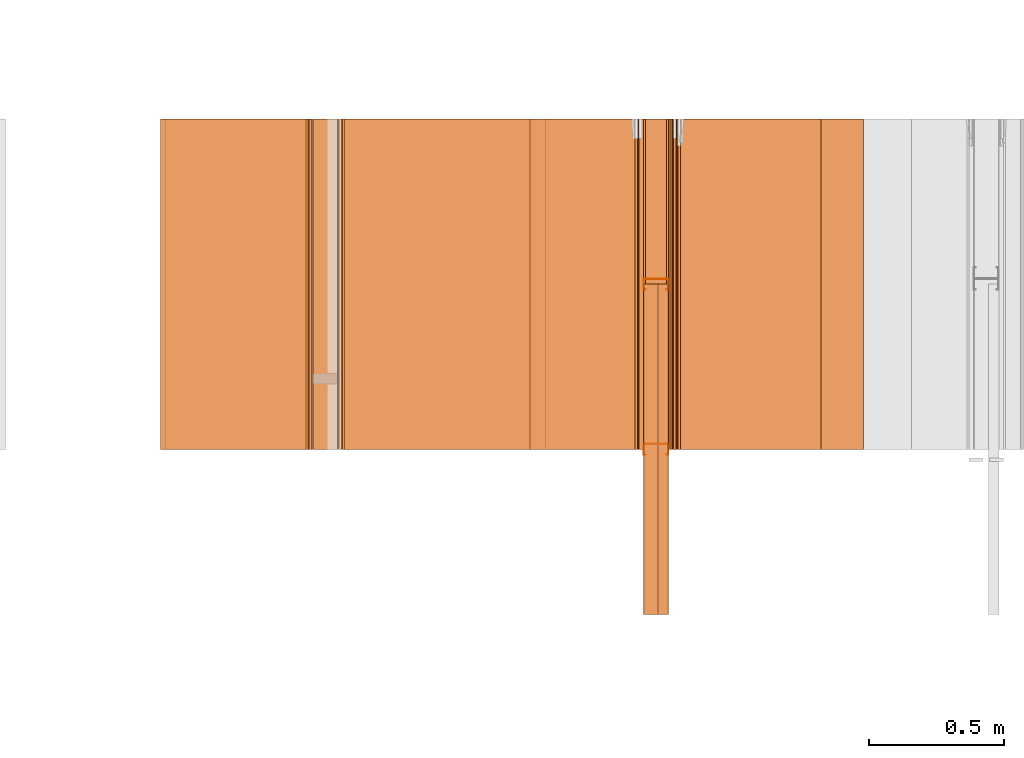
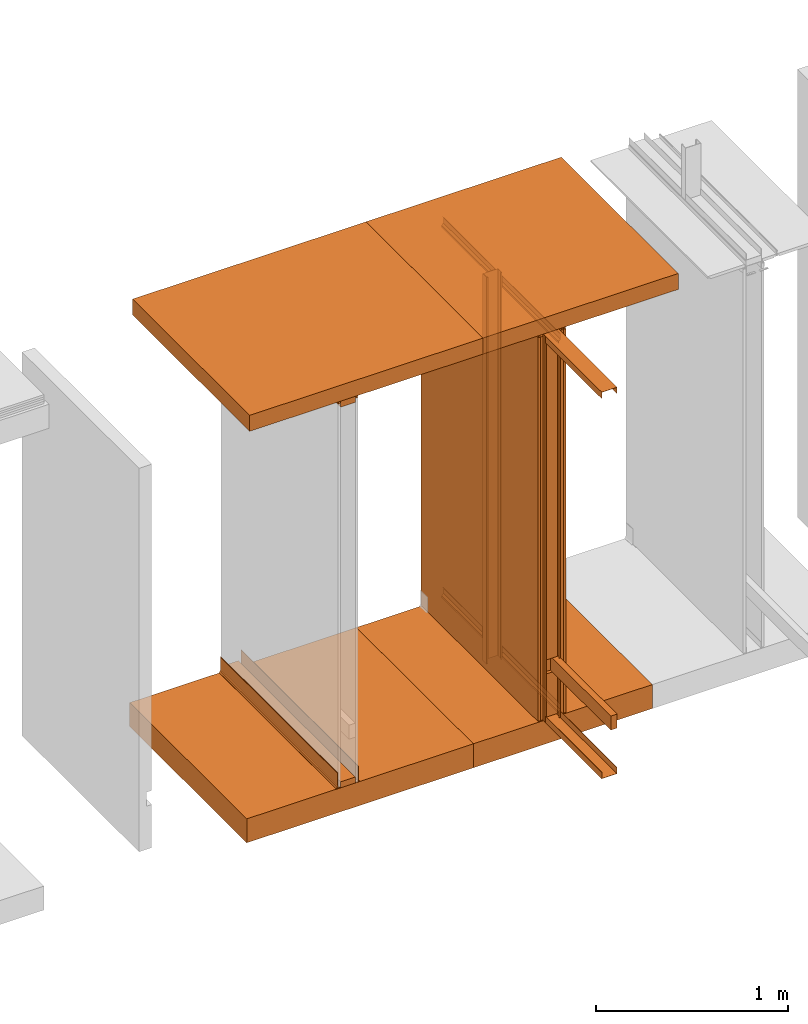
# One storey, part 37 of 64: 26 proxies.
"""IFC4 building model written with IfcOpenShell, lengths in feet."""

from ifc_helpers import new_model, entity, si_unit, converted_unit, frame, origin_with_axes, origin_2d_with_axis, place, context, subcontext, project, spatial, polyline, line, indexed_curve, outline, extrude, material, element, save


model = new_model("IFC4")

# Units and contexts
model_context_1 = context("Model", 3, precision=1e-05, world=origin_with_axes())
plan_context = context("Plan", 2, precision=1e-05, world=origin_2d_with_axis())
model_context_2 = context("Model", 3, precision=1e-05, world=origin_with_axes())
context_of_model_1 = context(None, 3, precision=1e-05, world=origin_with_axes())
context_of_model_2 = context(None, 3, precision=1e-05, world=origin_with_axes())
body_context = subcontext(model_context_2, "Body", "Model", "MODEL_VIEW")
ifc_project = project(units=[converted_unit("PLANEANGLEUNIT", "degree", entity("IfcReal", 0.0174532925199433), si_unit("PLANEANGLEUNIT", "RADIAN"), dimensions=[0, 0, 0, 0, 0, 0, 0]), converted_unit("AREAUNIT", "square foot", entity("IfcReal", 0.09290304), si_unit("AREAUNIT", "SQUARE_METRE"), dimensions=[2, 0, 0, 0, 0, 0, 0]), converted_unit("LENGTHUNIT", "foot", entity("IfcReal", 0.3048), si_unit("LENGTHUNIT", "METRE"), dimensions=[1, 0, 0, 0, 0, 0, 0]), converted_unit("VOLUMEUNIT", "cubic foot", entity("IfcReal", 0.0283168467116885), si_unit("VOLUMEUNIT", "CUBIC_METRE"), dimensions=[3, 0, 0, 0, 0, 0, 0])], contexts=[model_context_1, plan_context, context_of_model_1, context_of_model_2])

# Site, building, storey
site_placement = place(None, origin_with_axes())
site = spatial("IfcSite", under=ifc_project, at=site_placement)
building_placement = place(site_placement, origin_with_axes())
building = spatial("IfcBuilding", under=site, at=building_placement, Name="Building")
storey_placement = place(building_placement, origin_with_axes())
storey = spatial("IfcBuildingStorey", under=building, at=storey_placement, Name="Storey")

# Proxies
ifc_material_1 = material()
proxy_1_placement = place(storey_placement, frame((1399.03121107207, 4.00000004943587, 0.0), z_axis=(4.37113882867379e-08, -0.999999999999999, -8.51092183247426e-15), x_axis=(1.94707183709394e-07, 0.0, 0.999999999999981)))
element("IfcBuildingElementProxy", 1, at=proxy_1_placement, inside=storey, material=ifc_material_1, Name="Generic Models 522:Generic Models 1", PredefinedType="COMPLEX", context=body_context, shape_type="SweptSolid", body=[
    extrude(outline(polyline([(-0.145833333098669, 0.0638020740641071), (0.14583334532075, 0.0638020740641071), (0.14583334532075, -0.0664062573136933), (0.151041638487437, -0.0664062512026528), (0.151041638487437, 0.0690104100080769), (-0.151041662931599, 0.0690104100080769), (-0.151041662931599, -0.0664062512026528), (-0.145833333098669, -0.0664062512026528), (-0.145833333098669, 0.0638020740641071)])), frame((0.0690104405632795, -0.151041650709518, -1.80055678736589e-08), z_axis=(3.35954435928473e-13, 1.19208820592576e-07, -1.0), x_axis=(1.93807295545412e-07, -1.0, -1.19208884541422e-07)), (2.44568504337295e-10, -3.20892978855625e-10, -1.0), 4.00000000752362),
])
ifc_material_2 = material(Category="steel")
proxy_2_placement = place(storey_placement, frame((1399.03121107207, 4.00000004943587, 7.92708296788333), z_axis=(4.37113882867379e-08, -0.999999999999999, -8.51092183247426e-15), x_axis=(1.94707183709394e-07, 0.0, 0.999999999999981)))
element("IfcBuildingElementProxy", 2, at=proxy_2_placement, inside=storey, material=ifc_material_2, Name="Generic Models 525:Generic Models 1", PredefinedType="COMPLEX", context=body_context, shape_type="SweptSolid", body=[
    extrude(outline(polyline([(-0.151041650709518, -0.0690104161191174), (0.151041650709518, -0.0690104161191174), (0.151041650709518, 0.0664062512026528), (0.145833357542831, 0.0664062512026528), (0.145833357542831, -0.0638020862861881), (-0.145833320876588, -0.0638020862861881), (-0.145833320876588, 0.0664062450916122), (-0.151041650709518, 0.0664062450916122), (-0.151041650709518, -0.0690104161191174)])), frame((0.0664062756468148, -0.151041638487437, -1.80055678736589e-08), z_axis=(-2.47422091495531e-13, 1.19209389026764e-07, -1.0), x_axis=(2.0229651909176e-07, -0.999999940395355, -1.19209332183345e-07)), (2.58871729608146e-10, 2.48074564362932e-13, -1.0), 4.00000000752362),
])
ifc_material_3 = material(Name="ACOUSTICAL SEALANT OR FIRE SEALANT, IF RATED WALL", Category="sealant")
proxy_3_placement = place(storey_placement, frame((1399.43891310003, 5.99999987860051, 8.02083356486844), z_axis=(4.37113882867379e-08, -0.999999999999999, -8.51092183247426e-15), x_axis=(1.94707183709394e-07, 0.0, 0.999999999999981)))
element("IfcBuildingElementProxy", 3, at=proxy_3_placement, inside=storey, material=ifc_material_3, Name="Generic Models 526:Generic Models 1", PredefinedType="COMPLEX", context=body_context, shape_type="SweptSolid", body=[
    extrude(outline(polyline([(0.0294394396353034, 1.11674599467203e-10), (0.00735988588074804, 0.0221146120301147), (0.0007027826452838, 0.0216157494596844), (-0.00565191956965394, 0.0195703566993472), (-0.0113501409655364, 0.0160923909048826), (-0.0160743679186412, 0.01137565455969), (-0.019561362775468, 0.00568296136383427), (-0.0216168356971361, -0.000668488249788916), (-0.0221262596733379, -0.00732479781386616), (-4.67036271423805e-05, -0.0294394090801008), (0.0004627157657791, -0.0227831018076638), (0.00251818563192692, -0.01643164531912), (0.00600518659979418, -0.0107389559426646), (0.0107294143167791, -0.00602221806971185), (0.0164276318932612, -0.00254425151136721), (0.0227823379275993, -0.000498861424610253), (0.0294394396353034, 1.11674599467203e-10)])), frame((0.0208333330815585, -0.0194074470535155, -3.9342019289473e-07), z_axis=(5.16254628022544e-13, 1.19209111915097e-07, -1.0), x_axis=(-0.707667291164398, -0.706545770168304, -8.42232878994764e-08)), (8.58814885873471e-09, -6.92364210408414e-09, -1.0), 4.00000000752362),
])
ifc_material_4 = material()
proxy_4_placement = place(storey_placement, frame((1399.03121107207, 5.93229150521787, 0.00520833327038962), z_axis=(0.0, -0.999999999999999, -4.37113882867379e-08), x_axis=(1.0, 0.0, 0.0)))
element("IfcBuildingElementProxy", 4, at=proxy_4_placement, inside=storey, material=ifc_material_4, Name="Generic Models 531:Generic Models 65", PredefinedType="COMPLEX", context=body_context, shape_type="SweptSolid", body=[
    extrude(outline(polyline([(0.157892982673457, 1.2265641987067e-08), (0.132981374898921, 0.00758805456436838), (0.131463930206349, 0.00260531379208164), (0.151393255536638, -0.00346513108162116), (0.114970402963205, -0.123040838621733), (-0.164040004995864, -0.0380546715002986), (-0.127617164644513, 0.081521036039813), (-0.107687851536305, 0.0754505972771507), (-0.106170406843734, 0.0804333380494374), (-0.131082051284513, 0.0880213865027653), (-0.170539854353494, -0.041519390086685), (0.118435167382395, -0.129540761311849), (0.157892982673457, 1.2265641987067e-08)])), frame((0.150903101198942, -1.50282753870347e-06, 3.95394177261613), z_axis=(-2.26658865287721e-11, -1.0, -1.91150247701444e-05), x_axis=(0.956607103347778, -5.56963277631439e-06, 0.291381120681763)), (1.27116927615134e-05, -1.73452317540068e-05, -1.0), 8.05208292141328),
])
ifc_material_5 = material(Category="sand")
proxy_5_placement = place(storey_placement, frame((1399.37503444241, 5.99999987860051, 0.0208333330815585), z_axis=(4.37113882867379e-08, -0.999999999999999, -8.51092183247426e-15), x_axis=(1.94707183709394e-07, 0.0, 0.999999999999981)))
element("IfcBuildingElementProxy", 5, at=proxy_5_placement, inside=storey, material=ifc_material_5, Name="Generic Models 532:Generic Models 1", PredefinedType="COMPLEX", context=body_context, shape_type="SweptSolid", body=[
    extrude(outline(polyline([(-4.00000004943587, -0.0260416674977682), (4.00000004943587, -0.0260416674977682), (4.00000004943587, 0.0260416674977682), (-4.00000004943587, 0.0260416674977682), (-4.00000004943587, -0.0260416674977682)])), frame((4.00000004943587, -0.0260408883401024, -3.94211021364806e-07), z_axis=(-2.90393285860922e-14, 1.19209140336807e-07, -1.0), x_axis=(1.0, 1.94789421925634e-07, -5.82794243094743e-15)), (-1.26815158374427e-09, -4.3826126755464e-11, -1.0), 4.00000000752362),
])
proxy_6_placement = place(storey_placement, frame((1398.9791469624, 5.99999987860051, 0.0208333330815585), z_axis=(4.37113882867379e-08, -0.999999999999999, -8.51092183247426e-15), x_axis=(1.94707183709394e-07, 0.0, 0.999999999999981)))
element("IfcBuildingElementProxy", 6, at=proxy_6_placement, inside=storey, material=ifc_material_5, Name="Generic Models 533:Generic Models 1", PredefinedType="COMPLEX", context=body_context, shape_type="SweptSolid", body=[
    extrude(outline(polyline([(-0.0260424466554339, -4.00000004943587), (0.0260408883401024, -4.00000004943587), (0.0260424466554339, 4.00000004943587), (-0.0260408883401024, 4.00000004943587), (-0.0260424466554339, -4.00000004943587)])), frame((4.00000004943587, -0.0260408883401024, -3.94210974741267e-07), z_axis=(-2.90393285860922e-14, 1.19209140336807e-07, -1.0), x_axis=(0.0, -1.0, -1.19209147442234e-07)), (-4.38494379695342e-11, 2.89575899066821e-14, -1.0), 4.00000000752362),
])
ifc_material_6 = material(Name="2X WOOD TOP PLATE", Category="wood1")
proxy_7_placement = place(storey_placement, frame((1399.2083291682, 4.00000004943587, 0.955116717521287), z_axis=(4.37113882867379e-08, -0.999999999999999, -8.51092183247426e-15), x_axis=(1.94707183709394e-07, 0.0, 0.999999999999981)))
element("IfcBuildingElementProxy", 7, at=proxy_7_placement, inside=storey, material=ifc_material_6, Name="Generic Models 534:Generic Models 1", PredefinedType="COMPLEX", context=body_context, shape_type="SweptSolid", body=[
    extrude(outline(polyline([(-0.145833333098669, -0.0625000007724355), (0.145833333098669, -0.0625000007724355), (0.145833333098669, 0.062499994661395), (-0.145833333098669, 0.0625000007724355), (-0.145833333098669, -0.0625000007724355)])), frame((0.14583334532075, -0.0624999702172329, -7.45058214599091e-09), z_axis=(-3.48267083032615e-14, 1.19209289550781e-07, -1.0), x_axis=(1.0, 1.88569273973371e-07, -1.23475008158552e-14)), (1.09092013200751e-10, -8.07879596553818e-10, -1.0), 4.00000000752362),
])
ifc_material_7 = material(Category="InsulationBatt")
proxy_8_placement = place(storey_placement, frame((1399.0572431269, 5.99999987860051, 0.054687499912001), z_axis=(4.37113882867379e-08, -0.999999999999999, -8.51092183247426e-15), x_axis=(1.94707183709394e-07, 0.0, 0.999999999999981)))
element("IfcBuildingElementProxy", 8, at=proxy_8_placement, inside=storey, material=ifc_material_7, Name="Generic Models 536:Generic Models 1", PredefinedType="COMPLEX", context=body_context, shape_type="SweptSolid", body=[
    extrude(outline(polyline([(-2.52313129701639, -2.49999988423245), (5.47686860630206, -2.49999988423245), (5.47686860630206, 1.50000016520342), (-1.33103576153908, 1.50000016520342), (-1.33103576153908, -0.499999810626188), (-1.62270242773642, -0.499999810626188), (-1.62270242773642, 1.50000016520342), (-2.52313129701639, 1.50000016520342), (-2.52313129701639, -2.49999988423245)])), frame((2.52313129701639, -0.249999831980608, 2.49999949312586), z_axis=(1.96850052702757e-07, -1.0, -1.19976988344206e-07), x_axis=(1.0, 1.9555329799914e-07, 0.0)), (1.34042679299923e-13, 1.54440479502305e-13, -1.0), 0.250000000470226),
])
ifc_material_8 = material(Name="STRUCTURAL FLOOR", Category="concrete")
proxy_9_placement = place(storey_placement, frame((1397.18233443934, 5.99999987860051, -0.500000006179484), z_axis=(4.37113882867379e-08, -0.999999999999999, -8.51092183247426e-15), x_axis=(1.94707183709394e-07, 0.0, 0.999999999999981)))
element("IfcBuildingElementProxy", 9, at=proxy_9_placement, inside=storey, material=ifc_material_8, Name="Generic Models 537:Generic Models 1", PredefinedType="COMPLEX", context=body_context, shape_type="SweptSolid", body=[
    extrude(outline(indexed_curve([(-0.250000296419687, -1.52873036664302), (0.249999709759797, -1.52873036664302), (0.250000394196335, 2.00000002471794), (-0.249999611983149, 2.00000002471794)], segments=[line(4, 1), line(1, 2), line(2, 3), line(3, 4)], self_intersect=False)), frame((0.250000394196335, -2.00000002471794, -6.29525198374314e-07), z_axis=(0.0, 1.19209289550781e-07, -1.0), x_axis=(1.0, 0.0, 0.0)), (0.0, -2.1432619234929e-08, -1.0), 4.00000000752362),
])
ifc_material_9 = material(Name="UNDERSIDE OF FLOOR ASSEMBLY", Category="sand")
proxy_10_placement = place(storey_placement, frame((1397.69426480992, 5.99999987860051, 8.06249971464863), z_axis=(4.37113882867379e-08, -0.999999999999999, -8.51092183247426e-15), x_axis=(1.94707183709394e-07, 0.0, 0.999999999999981)))
element("IfcBuildingElementProxy", 10, at=proxy_10_placement, inside=storey, material=ifc_material_9, Name="Generic Models 538:Generic Models 1", PredefinedType="COMPLEX", context=body_context, shape_type="SweptSolid", body=[
    extrude(outline(indexed_curve([(-0.16666704353698, -1.85078093073187), (0.166666297990037, -1.85078093073187), (0.166667055759061, 2.00000002471794), (-0.166666285767956, 2.00000002471794)], segments=[line(4, 1), line(1, 2), line(2, 3), line(3, 4)], self_intersect=False)), frame((0.166667067981142, -2.00000002471794, -6.29525198374314e-07), z_axis=(0.0, 1.19209303761636e-07, -1.0), x_axis=(1.0, 0.0, 0.0)), (0.0, -2.14326316694269e-08, -1.0), 4.00000000752362),
])
proxy_11_placement = place(storey_placement, frame((1398.92708285274, 5.99999987860051, 0.0208333330815585), z_axis=(4.37113882867379e-08, -0.999999999999999, -8.51092183247426e-15), x_axis=(1.94707183709394e-07, 0.0, 0.999999999999981)))
element("IfcBuildingElementProxy", 11, at=proxy_11_placement, inside=storey, material=ifc_material_5, Name="Generic Models 541:Generic Models 1", PredefinedType="COMPLEX", context=body_context, shape_type="SweptSolid", body=[
    extrude(outline(polyline([(-4.00000004943587, -0.0260416674977682), (4.00000004943587, -0.0260416674977682), (4.00000004943587, 0.0260416674977682), (-4.00000004943587, 0.0260416674977682), (-4.00000004943587, -0.0260416674977682)])), frame((4.00000004943587, -0.0260408883401024, -3.94211021364806e-07), z_axis=(-2.90393285860922e-14, 1.19209140336807e-07, -1.0), x_axis=(1.0, 1.94789421925634e-07, -5.82794243094743e-15)), (-1.26815158374427e-09, -4.3826126755464e-11, -1.0), 4.00000000752362),
])
proxy_12_placement = place(storey_placement, frame((1399.33338315468, 5.99999987860051, 7.7598676906796), z_axis=(4.37113882867379e-08, -0.999999999999999, -8.51092183247426e-15), x_axis=(1.94707183709394e-07, 0.0, 0.999999999999981)))
element("IfcBuildingElementProxy", 12, at=proxy_12_placement, inside=storey, Name="Generic Models 542:Generic Models 1", PredefinedType="COMPLEX", context=body_context, shape_type="SweptSolid", body=[
    extrude(outline(polyline([(-0.0281511742396774, 0.0159932805220364), (0.089483129061035, 0.0159932805220364), (0.108790967681902, -0.00331456802927173), (0.112473822915022, 0.000368280376670051), (0.0916404974722643, 0.0212016149382461), (-0.0303085426509067, 0.0212016164660063), (-0.0667668820366146, -0.0152567168086611), (-0.106276176732982, -0.0152567152809009), (-0.106276176732982, -0.0204650512248708), (-0.0646095075143447, -0.0204650512248708), (-0.0281511742396774, 0.0159932805220364)])), frame((0.106276176732982, -0.0204650313639891, -3.93546169697356e-07), z_axis=(-2.61454616637402e-12, 1.19209516924457e-07, -1.0), x_axis=(1.0, 1.81823168077244e-07, -2.37805825378801e-12)), (-9.32653954066609e-10, -1.78575071396736e-10, -1.0), 4.00000000752362),
])
proxy_13_placement = place(storey_placement, frame((1399.42709855207, 5.99999987860051, 0.0208333330815585), z_axis=(4.37113882867379e-08, -0.999999999999999, -8.51092183247426e-15), x_axis=(1.94707183709394e-07, 0.0, 0.999999999999981)))
element("IfcBuildingElementProxy", 13, at=proxy_13_placement, inside=storey, material=ifc_material_5, Name="Generic Models 544:Generic Models 1", PredefinedType="COMPLEX", context=body_context, shape_type="SweptSolid", body=[
    extrude(outline(polyline([(-4.00000004943587, -0.0260416674977682), (4.00000004943587, -0.0260416674977682), (4.00000004943587, 0.0260416674977682), (-4.00000004943587, 0.0260416674977682), (-4.00000004943587, -0.0260416674977682)])), frame((4.00000004943587, -0.0260408883401024, -3.94211021364806e-07), z_axis=(-2.90393285860922e-14, 1.19209140336807e-07, -1.0), x_axis=(1.0, 1.94789421925634e-07, -5.82794243094743e-15)), (-1.26815158374427e-09, -4.3826126755464e-11, -1.0), 4.00000000752362),
])
proxy_14_placement = place(storey_placement, frame((1399.38684899037, 5.99999987860051, 8.02083356486844), z_axis=(4.37113882867379e-08, -0.999999999999999, -8.51092183247426e-15), x_axis=(1.94707183709394e-07, 0.0, 0.999999999999981)))
element("IfcBuildingElementProxy", 14, at=proxy_14_placement, inside=storey, material=ifc_material_3, Name="Generic Models 545:Generic Models 1", PredefinedType="COMPLEX", context=body_context, shape_type="SweptSolid", body=[
    extrude(outline(polyline([(0.0166234831029935, 2.78385270416865e-14), (0.0115247104766722, 0.0043091085541436), (0.00757805002716387, 0.00969332635520011), (0.00500340525579108, 0.0158526379800844), (0.00394425308148516, 0.0224438535044669), (0.00445958948938611, 0.029099699393345), (-0.0207445029966201, 0.0106249514263211), (-0.021259839404521, 0.00396910095416264), (-0.0202006830288747, -0.00262210998693946), (-0.0176260405491422, -0.00878142772286426), (-0.0136793808635138, -0.0141656394128803), (-0.00858060441779222, -0.0184747479670239), (-0.00261382494376009, -0.0214686383813463), (0.00388850091303897, -0.0229805067494472), (0.0290925953087453, -0.00450575572690313), (0.0225902694519463, -0.00299389194208258), (0.0166234831029935, 2.78385270416865e-14)])), frame((0.0208333346093186, -0.0194074501090358, -3.93420146271191e-07), z_axis=(-1.37667915262041e-12, 1.19209097704243e-07, -1.0), x_axis=(0.591192126274109, -0.806530773639679, -9.61472252924978e-08)), (8.31337931828102e-09, 7.05946234802468e-09, -1.0), 4.00000000752362),
])
proxy_15_placement = place(storey_placement, frame((1399.33338315468, 5.99999987860051, 0.0359095954470669), z_axis=(4.37113882867379e-08, -0.999999999999999, -8.51092183247426e-15), x_axis=(1.94707183709394e-07, 0.0, 0.999999999999981)))
element("IfcBuildingElementProxy", 15, at=proxy_15_placement, inside=storey, Name="Generic Models 548:Generic Models 1", PredefinedType="COMPLEX", context=body_context, shape_type="SweptSolid", body=[
    extrude(outline(polyline([(-0.0281511742396774, 0.0159932805220364), (0.089483129061035, 0.0159932805220364), (0.108790967681902, -0.00331456802927173), (0.112473822915022, 0.000368280376670051), (0.0916404974722643, 0.0212016149382461), (-0.0303085426509067, 0.0212016164660063), (-0.0667668820366146, -0.0152567168086611), (-0.106276176732982, -0.0152567152809009), (-0.106276176732982, -0.0204650512248708), (-0.0646095075143447, -0.0204650512248708), (-0.0281511742396774, 0.0159932805220364)])), frame((0.106276176732982, -0.0204650313639891, -3.93546169697356e-07), z_axis=(-2.61454616637402e-12, 1.19209516924457e-07, -1.0), x_axis=(1.0, 1.81823168077244e-07, -2.37805825378801e-12)), (-9.32653954066609e-10, -1.78575071396736e-10, -1.0), 4.00000000752362),
])
proxy_16_placement = place(storey_placement, frame((1394.97912149104, 5.99999987860051, 0.0), z_axis=(1.62920684942944e-07, -0.999999999999987, -1.23001694617954e-14), x_axis=(7.54979012640431e-08, 0.0, 0.999999999999997)))
element("IfcBuildingElementProxy", 16, at=proxy_16_placement, inside=storey, material=ifc_material_3, Name="Generic Models 31:Generic Models 1", PredefinedType="COMPLEX", context=body_context, shape_type="SweptSolid", body=[
    extrude(outline(polyline([(0.0175297305506124, -7.63880064481199e-10), (0.0150216877181816, 0.0110982958193174), (0.00514996557660264, 0.0167561690701939), (-0.0199842910842085, -0.00181347361657025), (-0.0101125697065096, -0.00747135049587707), (-0.00760452458243866, -0.0185696432596742), (0.0175297305506124, -7.63880064481199e-10)])), frame((0.0104166688324194, -0.0171509040935146, -3.91106593014374e-07), z_axis=(-2.29446561576807e-12, -1.36760807977204e-19, -1.0), x_axis=(0.594228744506836, -0.804296135902405, 0.0)), (1.52775991857368e-09, 1.84542702300061e-12, -1.0), 4.0),
])
ifc_material_10 = material(Name="WALL BASE AS SCHEDULED")
proxy_17_placement = place(storey_placement, frame((1394.94467908003, 5.99999987860051, 5.79880267455134e-13), z_axis=(1.62920684942944e-07, -0.999999999999987, -1.23001694617954e-14), x_axis=(7.54979012640431e-08, 0.0, 0.999999999999997)))
element("IfcBuildingElementProxy", 17, at=proxy_17_placement, inside=storey, material=ifc_material_10, Name="Generic Models 32:Generic Models 1", PredefinedType="COMPLEX", context=body_context, shape_type="SweptSolid", body=[
    extrude(outline(indexed_curve([(-0.218184337293695, 0.0328769396472321), (-0.217450963543469, 0.0363709942836148), (-0.214494099923632, 0.0406970731972709), (-0.209344228304277, 0.0416651934023526), (0.0605741857973922, -0.0149848457826717), (0.0730978466785486, -0.0159381818529854), (0.0854415129723511, -0.0136176685208645), (0.0967639877297121, -0.00818144882053841), (0.106293654308857, 6.9355880035885e-09), (0.11405258578813, -0.00695023609916838), (0.102459679154821, -0.0169030280681107), (0.0886858277159726, -0.0235162219497084), (0.0736696689616977, -0.0263391407279987), (0.0584345577367804, -0.0251794027365021)], segments=[line(4, 3), line(3, 2), line(2, 1), line(1, 14), line(14, 13), line(13, 12), line(12, 11), line(11, 10), line(10, 9), line(9, 8), line(8, 7), line(7, 6), line(6, 5), line(5, 4)], self_intersect=False)), frame((0.113048297389755, -0.021833058060428, -3.91106686261452e-07), z_axis=(-8.52253109664275e-14, 0.0, -1.0), x_axis=(-0.97867751121521, 0.205403223633766, 4.3862957428524e-13)), (-2.68380464518714e-08, -6.31495522540604e-09, -1.0), 4.0),
])
proxy_18_placement = place(storey_placement, frame((1395.37490884776, 5.99999987860051, -3.32751528285302e-08), z_axis=(1.62920684942944e-07, -0.999999999999987, -1.23001694617954e-14), x_axis=(7.54979012640431e-08, 0.0, 0.999999999999997)))
element("IfcBuildingElementProxy", 18, at=proxy_18_placement, inside=storey, material=ifc_material_10, Name="Generic Models 32:Generic Models 1", PredefinedType="COMPLEX", context=body_context, shape_type="SweptSolid", body=[
    extrude(outline(indexed_curve([(0.0992190677017521, -0.0337080381018674), (0.0937828510569462, -0.0223855664000267), (0.0856013961253673, -0.012855893709841), (0.0752322559105599, -0.00576845252901081), (0.0633820683604932, -0.00160624269454733), (-0.206536327408055, 0.0550438163513587), (-0.210862406321711, 0.0580007349705602), (-0.21183049291607, 0.0631505699236718), (-0.21109719249833, 0.0666446428931761), (0.065521671976943, 0.00858831960644348), (0.0799375004440624, 0.00352496618901201), (0.0925516352800559, -0.0050969576472881), (0.102504418082437, -0.0166898596973166), (0.109117615019555, -0.0304637203027257)], segments=[line(9, 8), line(8, 7), line(7, 6), line(6, 5), line(5, 4), line(4, 3), line(3, 2), line(2, 1), line(1, 14), line(14, 13), line(13, 12), line(12, 11), line(11, 10), line(10, 9)], self_intersect=False)), frame((0.113048297389755, -0.021833058060428, -3.91106686261452e-07), z_axis=(-8.52253109664275e-14, 0.0, -1.0), x_axis=(-0.97867751121521, 0.205403223633766, 4.3862957428524e-13)), (-2.68380464518714e-08, -6.31495522540604e-09, -1.0), 4.0),
])
proxy_19_placement = place(storey_placement, frame((1393.18230896797, 5.99999987860051, -0.500000006179484), z_axis=(1.62920684942944e-07, -0.999999999999987, -1.23001694617954e-14), x_axis=(7.54979012640431e-08, 0.0, 0.999999999999997)))
element("IfcBuildingElementProxy", 19, at=proxy_19_placement, inside=storey, material=ifc_material_8, Name="Generic Models 446:Generic Models 1", PredefinedType="COMPLEX", context=body_context, shape_type="SweptSolid", body=[
    extrude(outline(indexed_curve([(-2.47129911356398, -0.250000003089742), (2.00000002471794, -0.250000003089742), (2.00000002471794, 0.250000003089742), (-2.47129911356398, 0.24999997864558)], segments=[line(4, 1), line(1, 2), line(2, 3), line(3, 4)], self_intersect=False)), frame((0.250000149754714, -2.00000002471794, -3.075043623215e-15), z_axis=(-1.23001652266308e-14, 0.0, -1.0), x_axis=(-7.33324867496776e-08, 1.0, 8.30772315187161e-22)), (-4.58328353047932e-09, -1.23046985469645e-14, -1.0), 4.00000000752362),
])
proxy_20_placement = place(storey_placement, frame((1393.2395794886, 5.99999987860051, 8.06249971464863), z_axis=(1.62920684942944e-07, -0.999999999999987, -1.23001694617954e-14), x_axis=(7.54979012640431e-08, 0.0, 0.999999999999997)))
element("IfcBuildingElementProxy", 20, at=proxy_20_placement, inside=storey, material=ifc_material_9, Name="Generic Models 447:Generic Models 1", PredefinedType="COMPLEX", context=body_context, shape_type="SweptSolid", body=[
    extrude(outline(indexed_curve([(2.00000002471794, -0.166666725762873), (2.00000002471794, 0.166666652430387), (-2.60384357351018, 0.166666591319982), (-2.60384357351018, -0.166666725762873)], segments=[line(3, 2), line(2, 1), line(1, 4), line(4, 3)], self_intersect=False)), frame((0.166666823539521, -2.00000002471794, -2.05003006636523e-15), z_axis=(-1.23001694617955e-14, 5.34221906160952e-23, -1.0), x_axis=(-7.63880052545574e-08, 1.0, 9.93007606175839e-22)), (-3.18283643885309e-09, -1.52777257511616e-09, -1.0), 4.00000000752362),
])
proxy_21_placement = place(storey_placement, frame((1398.92708285274, 5.99999987860051, 8.02083356486844), z_axis=(2.82129974493717e-07, -0.99999999999996, -2.13002206340563e-14), x_axis=(7.54979012640431e-08, 0.0, 0.999999999999997)))
element("IfcBuildingElementProxy", 21, at=proxy_21_placement, inside=storey, material=ifc_material_3, Name="Generic Models 526:Generic Models 1", PredefinedType="COMPLEX", context=body_context, shape_type="SweptSolid", body=[
    extrude(outline(polyline([(0.0216271725221686, -3.8197440799452e-10), (0.0223420985688375, 0.00663738214383953), (0.000956643575507893, 0.0294238931482311), (0.000241720106934253, 0.0227865224625925), (-0.00200908783251258, 0.0165016304828676), (-0.00567038331469252, 0.0109194417048999), (-0.0105381410402732, 0.00635097906350346), (-0.01634113775356, 0.00305080826374705), (-0.0227560314259387, 0.00120281376124279), (-0.0294253781310764, 0.000909959045367125), (-0.00803992781651223, -0.0218765595023401), (-0.00137057500033397, -0.0215836970521787), (0.00504431256100418, -0.0197357015948244), (0.0108473123298112, -0.0164355349964083), (0.0157150677637517, -0.0118670746466521), (0.0193763647736918, -0.00628487746600365), (0.0216271725221686, -3.8197440799452e-10)])), frame((0.0208333330815585, -0.0208421131190196, -3.9359116141258e-07), z_axis=(5.7361620065411e-14, 1.1920896980655e-07, -1.0), x_axis=(-0.729168355464935, -0.684334337711334, -8.15792304820206e-08)), (8.17668510677549e-09, -7.03388947087547e-09, -1.0), 4.00000000752362),
])
proxy_22_placement = place(storey_placement, frame((1394.97912149104, 5.99999870528073, 8.02083356486844), z_axis=(2.82129974493717e-07, -0.99999999999996, -2.13002206340563e-14), x_axis=(7.54979012640431e-08, 0.0, 0.999999999999997)))
element("IfcBuildingElementProxy", 22, at=proxy_22_placement, inside=storey, material=ifc_material_3, Name="Generic Models 526:Generic Models 1", PredefinedType="COMPLEX", context=body_context, shape_type="SweptSolid", body=[
    extrude(outline(indexed_curve([(0.0293439240720407, -0.00822231487622802), (0.0300588485909494, -0.00158493225496345), (0.000956644434872966, 0.0294238900927108), (0.00024172029790427, 0.0227865224625925), (-0.00200908783251258, 0.0165016289551075), (-0.00567038255081246, 0.0109194409410198), (-0.0105381395125131, 0.00635097753574333), (-0.0163411362257999, 0.00305080711792695), (-0.0227560298981785, 0.00120281299736273), (-0.0294253781310764, 0.0009099587589121), (-0.00032317626664019, -0.0300988728508079), (0.00634617502177794, -0.0298060104006466), (0.0127610625831161, -0.0279580164710524), (0.0185640638796833, -0.0246578498726364), (0.0234318162581035, -0.0200893857034798), (0.0270931147958037, -0.0145071915783516)], segments=[line(2, 1), line(1, 16), line(16, 15), line(15, 14), line(14, 13), line(13, 12), line(12, 11), line(11, 10), line(10, 9), line(9, 8), line(8, 7), line(7, 6), line(6, 5), line(5, 4), line(4, 3), line(3, 2)], self_intersect=False)), frame((0.0208333330815585, -0.0208421131190196, -3.9359116141258e-07), z_axis=(5.7361620065411e-14, 1.1920896980655e-07, -1.0), x_axis=(-0.729168355464935, -0.684334337711334, -8.15792304820206e-08)), (8.17668510677549e-09, -7.03388947087547e-09, -1.0), 4.00000000752362),
])
proxy_23_placement = place(storey_placement, frame((1395.38542179298, 5.99999870528073, 8.06249971464863), z_axis=(3.13916473260163e-07, -0.999999999999951, 3.74341637061104e-15), x_axis=(1.19248806385031e-08, 0.0, -1.0)))
element("IfcBuildingElementProxy", 23, at=proxy_23_placement, inside=storey, material=ifc_material_3, Name="Generic Models 526:Generic Models 1", PredefinedType="COMPLEX", context=body_context, shape_type="SweptSolid", body=[
    extrude(outline(indexed_curve([(-0.0193083718091523, -0.00247071736083999), (-0.0128934781367737, -0.000622722667365719), (-0.00709048371512707, 0.00267744775045067), (-0.00222272751730649, 0.00724591115572712), (0.00143856872875351, 0.0128280991698148), (0.0036893760952903, 0.01911299420506), (0.00440430061419903, 0.0257503603074181), (0.0301327035711037, -0.00166362345529099), (0.029417779052195, -0.00830100674495062), (0.0271669728314783, -0.0145858849748343), (0.0235056742937781, -0.0201680745166822), (0.0186379173320774, -0.0247365402135988), (0.0128349206187907, -0.0280367113952953), (0.00642003000193224, -0.0298847022693692), (-0.00024932128648589, -0.0301775647195305), (-0.0259777215698103, -0.00276356988056047)], segments=[line(2, 1), line(1, 16), line(16, 15), line(15, 14), line(14, 13), line(13, 12), line(12, 11), line(11, 10), line(10, 9), line(9, 8), line(8, 7), line(7, 6), line(6, 5), line(5, 4), line(4, 3), line(3, 2)], self_intersect=False)), frame((0.0208333330815585, -0.0208421131190196, -3.9359116141258e-07), z_axis=(5.7361620065411e-14, 1.1920896980655e-07, -1.0), x_axis=(-0.729168355464935, -0.684334337711334, -8.15792304820206e-08)), (8.17668510677549e-09, -7.03388947087547e-09, -1.0), 4.00000000752362),
])
proxy_24_placement = place(storey_placement, frame((1399.03121107207, 3.93229167605322, 0.00520833327038962), z_axis=(0.0, 0.0, 1.0), x_axis=(1.0, 0.0, 0.0)))
element("IfcBuildingElementProxy", 24, at=proxy_24_placement, inside=storey, material=ifc_material_4, Name="Generic Models 581:Generic Models 65", PredefinedType="COMPLEX", context=body_context, shape_type="SweptSolid", body=[
    extrude(outline(polyline([(-0.0842013872983887, 0.145833333098669), (0.040798611190962, 0.145833333098669), (0.040798611190962, 0.12499998932279), (0.0460069440794116, 0.12499998932279), (0.0460069440794116, 0.151041662931599), (-0.0894097171313181, 0.151041662931599), (-0.0894097171313181, -0.151041638487437), (0.0460069440794116, -0.151041638487437), (0.0460069440794116, -0.125000001544871), (0.040798611190962, -0.125000001544871), (0.040798611190962, -0.14583334532075), (-0.0842013872983887, -0.14583334532075), (-0.0842013872983887, 0.145833333098669)])), frame((0.151041662931599, 0.0460069440794116, 0.0), z_axis=(0.0, 0.0, -1.0), x_axis=(0.0, -1.0, 0.0)), (0.0, 0.0, -1.0), 8.0676348771059),
])
ifc_material_11 = material(Category="wood1")
proxy_25_placement = place(storey_placement, frame((1395.0311856007, 5.99999987860051, 0.125000001544871), z_axis=(2.82129946071984e-07, -0.99999999999988, -4.01339264044461e-07), x_axis=(0.999999999999953, 2.82130002915424e-07, -1.19209211391075e-07)))
element("IfcBuildingElementProxy", 25, at=proxy_25_placement, inside=storey, material=ifc_material_11, Name="Generic Models 197:Generic Models 1", PredefinedType="COMPLEX", context=body_context, shape_type="SweptSolid", body=[
    extrude(outline(polyline([(-0.0625000007724355, -0.145833333098669), (0.0625000007724355, -0.145833333098669), (0.062499994661395, 0.145833333098669), (-0.062500006883476, 0.145833320876588), (-0.0625000007724355, -0.145833333098669)])), frame((0.145833333098669, -0.0624999885503545, -3.91106593014374e-07), z_axis=(0.0, 0.0, -1.0), x_axis=(-9.77766489995702e-08, 1.0, 0.0)), (-5.09253250680075e-10, -1.52775991857368e-09, -1.0), 4.00000000752362),
])
proxy_26_placement = place(storey_placement, frame((1395.0311856007, 5.99999987860051, 8.06250049686182), z_axis=(2.82129946071984e-07, -0.99999999999988, -4.01339264044461e-07), x_axis=(0.999999999999953, 2.82130002915424e-07, -1.19209211391075e-07)))
element("IfcBuildingElementProxy", 26, at=proxy_26_placement, inside=storey, material=ifc_material_6, Name="Generic Models 197:Generic Models 1", PredefinedType="COMPLEX", context=body_context, shape_type="SweptSolid", body=[
    extrude(outline(polyline([(-0.0625000129945165, -0.145833333098669), (0.0624999885503545, -0.145833333098669), (0.0625000129945165, 0.145833320876588), (-0.0624999885503545, 0.145833333098669), (-0.0625000129945165, -0.145833333098669)])), frame((0.145833333098669, -0.0624999885503545, -3.91106593014374e-07), z_axis=(0.0, 0.0, -1.0), x_axis=(0.0, -1.0, 0.0)), (0.0, 0.0, -1.0), 4.00000000752362),
])

save(model, "model.ifc")
